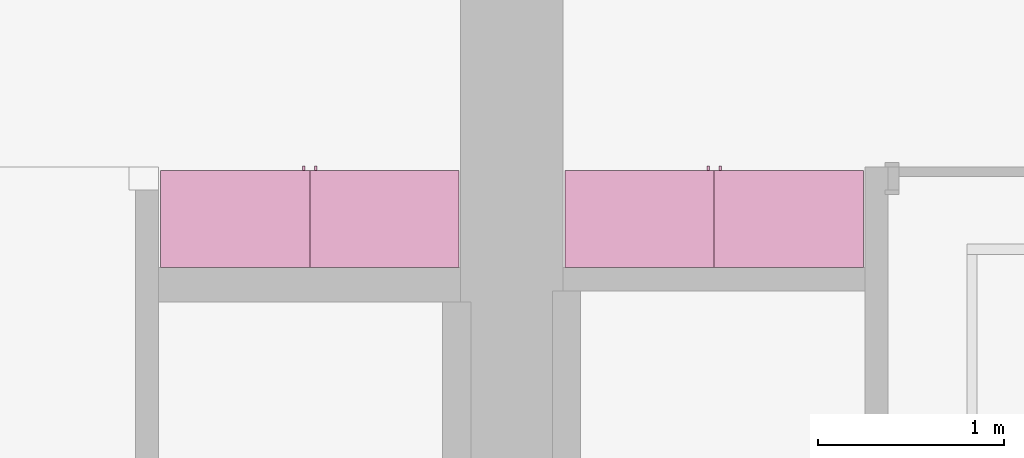
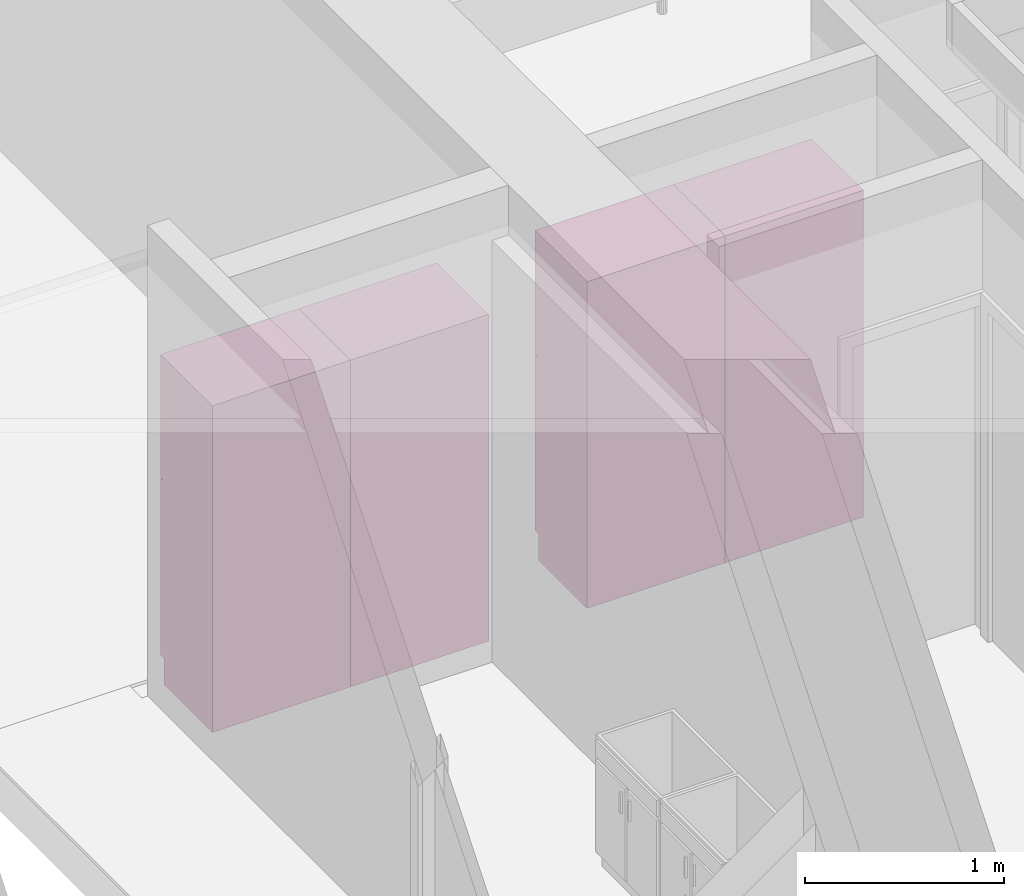
# One storey, part 12 of 12: 4 furnishings, 4 openings.
"""IFC2X3 building model written with IfcOpenShell, lengths in metres."""

from ifc_helpers import new_model, entity, si_unit, converted_unit, frame, origin, origin_2d_with_axis, place, context, project, spatial, rectangle, extrude, face_set, surface_model, source, transform, mapped, type_object, type_shapes, element, save


model = new_model("IFC2X3")

# Units and contexts
model_context = context("Model", 3, precision=1e-09, world=origin())
plan_context = context("Plan", 3, precision=1e-09, world=origin())
ifc_project = project(units=[si_unit("LENGTHUNIT", "METRE"), si_unit("AREAUNIT", "SQUARE_METRE"), si_unit("VOLUMEUNIT", "CUBIC_METRE"), converted_unit("PLANEANGLEUNIT", "DEGREE", entity("IfcRatioMeasure", 0.0174532925199433), si_unit("PLANEANGLEUNIT", "RADIAN"), dimensions=[0, 0, 0, 0, 0, 0, 0]), si_unit("TIMEUNIT", "SECOND")], contexts=[model_context, plan_context])

# Site, building, storey, space
site_placement = place(None, origin())
site = spatial("IfcSite", under=ifc_project, at=site_placement, CompositionType="ELEMENT")
building_placement = place(site_placement, origin())
building = spatial("IfcBuilding", under=site, at=building_placement, CompositionType="ELEMENT")
storey_placement = place(building_placement, frame((0.0, 0.0, 3.10000000000038)))
storey = spatial("IfcBuildingStorey", under=building, at=storey_placement, Name="Level 2", CompositionType="ELEMENT", Elevation=3.10000000000038)
space_1_placement = place(storey_placement, origin())
space_1 = spatial("IfcSpace", under=storey, at=space_1_placement, CompositionType="ELEMENT", InteriorOrExteriorSpace="INTERNAL")

# Furnishing, opening
furniture_type_1 = type_object("IfcFurnitureType", Name="800 mm", AssemblyPlace="NOTDEFINED")
shared_shape_1 = source(origin(), model_context, "Body", "SurfaceModel", [
    surface_model("IfcFaceBasedSurfaceModel", [(0.8, 0.0444499999999999, 0.161587499999842), (0.0, 0.0444500000000025, 0.161587499999842), (0.0, 0.0444500000000025, 2.0), (0.8, 0.0444499999999999, 2.0), (0.780949999999997, 0.04445, 1.98094999999995), (0.0190499999999982, 0.0444500000000025, 1.98094999999995), (0.0190499999999982, 0.0444500000000025, 0.180637499999843), (0.780949999999997, 0.04445, 0.180637499999843), (0.0, 0.545400000000002, 2.0), (0.800000000000001, 0.5454, 2.0), (0.800000000000003, 0.5454, 0.0), (0.0, 0.545400000000001, 0.0), (0.780949999999999, 0.5454, 1.98094999999995), (0.0190499999999998, 0.545400000000002, 1.98094999999995), (0.0190499999999998, 0.545400000000002, 0.180637499999843), (0.780949999999999, 0.5454, 0.180637499999843), (0.8, 0.0604000000000018, 0.161587499999842), (0.8, 0.0604000000000018, 0.0), (0.0, 0.0604000000000018, 0.0), (0.0, 0.0604000000000018, 0.161587499999832), (0.7746, 0.0, 1.37154803669582), (0.7746, 0.0, 1.26994803669581), (0.762067768369355, 0.0, 1.26994803669581), (0.762067768369355, 0.0, 1.37154803669582), (0.774599999999999, 0.0, 1.21914803669582), (0.774599999999999, 0.0, 1.11754803669582), (0.762067768369354, 0.0, 1.11754803669582), (0.762067768369354, 0.0, 1.21914803669582), (0.7746, 0.0254, 1.37154803669582), (0.7746, 0.0254, 1.26994803669581), (0.762067768369356, 0.0254000000000001, 1.26994803669581), (0.762067768369356, 0.0254000000000001, 1.37154803669582), (0.774599999999999, 0.0254, 1.21914803669582), (0.774599999999999, 0.0254, 1.11754803669582), (0.762067768369354, 0.0254000000000001, 1.11754803669582), (0.762067768369354, 0.0254000000000001, 1.21914803669582), (0.7365, 0.0381000000000001, 1.93649999999996), (0.7365, 0.0381000000000001, 1.30804803669582), (0.0635000000000013, 0.0381000000000023, 1.30804803669582), (0.0635000000000013, 0.0381000000000023, 1.93649999999996), (0.736499999999999, 0.0381000000000001, 1.18104803669581), (0.736499999999999, 0.0381000000000001, 0.22508749999984), (0.0635000000000007, 0.0381000000000023, 0.22508749999984), (0.0635000000000007, 0.0381000000000023, 1.18104803669581), (0.7365, 0.0444500000000001, 1.93649999999996), (0.7365, 0.0444500000000001, 1.30804803669582), (0.0635000000000013, 0.0444500000000023, 1.30804803669582), (0.0635000000000013, 0.0444500000000023, 1.93649999999996), (0.736499999999999, 0.0444500000000001, 1.18104803669581), (0.736499999999999, 0.0444500000000001, 0.22508749999984), (0.0635000000000007, 0.0444500000000023, 0.22508749999984), (0.0635000000000007, 0.0444500000000023, 1.18104803669581), (0.8, 0.0253999999999998, 2.0), (0.8, 0.0253999999999998, 1.24772303669581), (0.0, 0.0254000000000025, 1.24772303669581), (0.0, 0.0254000000000025, 2.0), (0.7365, 0.0254000000000001, 1.93649999999996), (0.0635000000000012, 0.0254000000000023, 1.93649999999996), (0.0635000000000012, 0.0254000000000023, 1.30804803669582), (0.7365, 0.0254000000000001, 1.30804803669582), (0.8, 0.0253999999999998, 0.161587499999821), (0.0, 0.0254000000000025, 0.161587499999821), (0.0, 0.0254000000000025, 1.24137303669581), (0.8, 0.0253999999999998, 1.24137303669581), (0.736499999999999, 0.0254000000000001, 1.18104803669582), (0.0635000000000007, 0.0254000000000023, 1.18104803669582), (0.0635000000000007, 0.0254000000000023, 0.22508749999984), (0.736499999999999, 0.0254000000000001, 0.22508749999984), (0.8, 0.0444499999999998, 2.0), (0.8, 0.0444499999999998, 1.24772303669581), (0.0, 0.0444500000000025, 1.24772303669581), (0.0, 0.0444500000000025, 2.0), (0.7365, 0.0444500000000001, 1.93649999999996), (0.0635000000000013, 0.0444500000000023, 1.93649999999996), (0.0635000000000013, 0.0444500000000023, 1.30804803669582), (0.7365, 0.0444500000000001, 1.30804803669582), (0.8, 0.0444499999999998, 0.161587499999821), (0.0, 0.0444500000000025, 0.161587499999821), (0.0, 0.0444500000000025, 1.24137303669581), (0.8, 0.0444499999999998, 1.24137303669581), (0.736499999999999, 0.0444500000000001, 1.18104803669582), (0.0635000000000007, 0.0444500000000023, 1.18104803669582), (0.0635000000000007, 0.0444500000000023, 0.22508749999984), (0.736499999999999, 0.0444500000000001, 0.22508749999984), (0.780949999999999, 0.526350000000001, 1.98094999999995), (0.780949999999999, 0.526350000000001, 0.180637499999846), (0.0190499999999999, 0.526350000000001, 0.180637499999846), (0.0190499999999998, 0.526350000000001, 1.98094999999995), (0.780949999999999, 0.545400000000001, 1.98094999999995), (0.780949999999999, 0.545400000000001, 0.180637499999846), (0.0190499999999998, 0.545400000000001, 0.180637499999846), (0.0190499999999998, 0.545400000000001, 1.98094999999995)], [face_set([[[0, 1, 2, 3], [4, 5, 6, 7]], [[8, 9, 10, 11], [12, 13, 14, 15]], [[3, 0, 16, 17, 10, 9]], [[2, 8, 9, 3]], [[1, 2, 8, 11, 18, 19]], [[0, 1, 19, 16]], [[7, 15, 12, 4]], [[6, 14, 15, 7]], [[5, 13, 14, 6]], [[4, 5, 13, 12]], [[10, 17, 18, 11]], [[18, 19, 16, 17]]]), face_set([[[20, 21, 22, 23]], [[24, 25, 26, 27]], [[28, 29, 30, 31]], [[32, 33, 34, 35]], [[23, 31, 28, 20]], [[22, 23, 31, 30]], [[21, 22, 30, 29]], [[20, 28, 29, 21]], [[27, 35, 32, 24]], [[26, 27, 35, 34]], [[25, 26, 34, 33]], [[24, 32, 33, 25]]]), face_set([[[36, 37, 38, 39]], [[40, 41, 42, 43]], [[44, 45, 46, 47]], [[48, 49, 50, 51]], [[39, 47, 44, 36]], [[38, 46, 47, 39]], [[37, 38, 46, 45]], [[36, 37, 45, 44]], [[43, 51, 48, 40]], [[42, 50, 51, 43]], [[41, 42, 50, 49]], [[40, 41, 49, 48]]]), face_set([[[52, 53, 54, 55], [56, 57, 58, 59]], [[60, 61, 62, 63], [64, 65, 66, 67]], [[68, 69, 70, 71], [72, 73, 74, 75]], [[76, 77, 78, 79], [80, 81, 82, 83]], [[55, 71, 68, 52]], [[54, 55, 71, 70]], [[53, 54, 70, 69]], [[52, 53, 69, 68]], [[63, 60, 76, 79]], [[62, 78, 79, 63]], [[61, 62, 78, 77]], [[60, 61, 77, 76]], [[59, 75, 72, 56]], [[58, 74, 75, 59]], [[57, 58, 74, 73]], [[56, 57, 73, 72]], [[67, 83, 80, 64]], [[66, 82, 83, 67]], [[65, 66, 82, 81]], [[64, 65, 81, 80]]]), face_set([[[84, 85, 86, 87]], [[88, 89, 90, 91]], [[87, 91, 88, 84]], [[86, 87, 91, 90]], [[85, 86, 90, 89]], [[84, 85, 89, 88]]])]),
])
type_shapes(furniture_type_1, [shared_shape_1])
furnishing_1_placement = place(space_1_placement, frame((6.28600000000001, -6.12060000000001, 0.0), z_axis=(0.0, 0.0, 1.0), x_axis=(-1.0, 0.0, 0.0)))
furnishing_1 = element("IfcFurnishingElement", 1, at=furnishing_1_placement, inside=space_1, type_object=furniture_type_1, ObjectType="800 mm", context=model_context, shape_type="MappedRepresentation", body=[
    mapped(shared_shape_1, transform((0.0, 0.0, 0.0), scale=1.0)),
])
opening_1_placement = place(space_1_placement, frame((6.28600000000001, -6.12060000000001, 0.0), z_axis=(0.0, 0.0, 1.0), x_axis=(-1.0, 0.0, 0.0)))
element("IfcOpeningElement", 2, at=opening_1_placement, cuts=furnishing_1, ObjectType="Opening", context=model_context, shape_type="SweptSolid", body=[
    extrude(rectangle(XDim=1.80031250000011, YDim=0.761899999999999, at=origin_2d_with_axis()), frame((-0.0187377049180267, 0.50095, -2.01920625000048), z_axis=(0.0, -1.0, 0.0), x_axis=(0.0, 0.0, -1.0)), (0.0, 0.0, 1.0), 0.50095),
])

furniture_type_2 = type_object("IfcFurnitureType", Name="800 mm", AssemblyPlace="NOTDEFINED")
shared_shape_2 = source(origin(), model_context, "Body", "SurfaceModel", [
    surface_model("IfcFaceBasedSurfaceModel", [(0.8, 0.500950000000002, 0.161587499999842), (0.8, 0.500950000000002, 2.0), (0.0, 0.50095, 2.0), (0.0, 0.50095, 0.161587499999842), (0.780949999999997, 0.500950000000002, 1.98094999999995), (0.780949999999997, 0.500950000000002, 0.180637499999843), (0.0190499999999982, 0.50095, 0.180637499999843), (0.0190499999999982, 0.50095, 1.98094999999995), (0.0, 0.0, 2.0), (0.0, 0.0, 0.0), (0.800000000000003, 0.0, 0.0), (0.800000000000001, 0.0, 2.0), (0.780949999999999, 0.0, 1.98094999999995), (0.780949999999999, 0.0, 0.180637499999843), (0.0190499999999998, 0.0, 0.180637499999843), (0.0190499999999998, 0.0, 1.98094999999995), (0.800000000000003, 0.485, 0.0), (0.8, 0.485, 0.161587499999832), (0.0, 0.485, 0.0), (0.0, 0.485, 0.161587499999842), (0.7746, 0.545400000000002, 1.37154803669582), (0.762067768369355, 0.545400000000002, 1.37154803669582), (0.762067768369355, 0.545400000000002, 1.26994803669581), (0.7746, 0.545400000000002, 1.26994803669581), (0.774599999999999, 0.545400000000002, 1.21914803669582), (0.762067768369354, 0.545400000000002, 1.21914803669582), (0.762067768369354, 0.545400000000002, 1.11754803669582), (0.774599999999999, 0.545400000000002, 1.11754803669582), (0.7746, 0.520000000000002, 1.37154803669582), (0.762067768369356, 0.520000000000002, 1.37154803669582), (0.762067768369356, 0.520000000000002, 1.26994803669581), (0.7746, 0.520000000000002, 1.26994803669581), (0.774599999999999, 0.520000000000002, 1.21914803669582), (0.762067768369354, 0.520000000000002, 1.21914803669582), (0.762067768369354, 0.520000000000002, 1.11754803669582), (0.774599999999999, 0.520000000000002, 1.11754803669582), (0.7365, 0.507300000000002, 1.93649999999996), (0.0635000000000013, 0.5073, 1.93649999999996), (0.0635000000000013, 0.5073, 1.30804803669582), (0.7365, 0.507300000000002, 1.30804803669582), (0.736499999999999, 0.507300000000002, 1.18104803669581), (0.0635000000000007, 0.5073, 1.18104803669581), (0.0635000000000007, 0.5073, 0.22508749999984), (0.736499999999999, 0.507300000000002, 0.22508749999984), (0.7365, 0.500950000000002, 1.93649999999996), (0.0635000000000013, 0.50095, 1.93649999999996), (0.0635000000000013, 0.50095, 1.30804803669582), (0.7365, 0.500950000000002, 1.30804803669582), (0.736499999999999, 0.500950000000002, 1.18104803669581), (0.0635000000000007, 0.50095, 1.18104803669581), (0.0635000000000007, 0.50095, 0.22508749999984), (0.736499999999999, 0.500950000000002, 0.22508749999984), (0.8, 0.520000000000002, 2.0), (0.0, 0.52, 2.0), (0.0, 0.52, 1.24772303669581), (0.8, 0.520000000000002, 1.24772303669581), (0.7365, 0.520000000000002, 1.93649999999996), (0.7365, 0.520000000000002, 1.30804803669582), (0.0635000000000012, 0.52, 1.30804803669582), (0.0635000000000012, 0.52, 1.93649999999996), (0.8, 0.520000000000002, 0.161587499999821), (0.8, 0.520000000000002, 1.24137303669581), (0.0, 0.52, 1.24137303669581), (0.0, 0.52, 0.161587499999821), (0.736499999999999, 0.520000000000002, 1.18104803669582), (0.736499999999999, 0.520000000000002, 0.22508749999984), (0.0635000000000007, 0.52, 0.22508749999984), (0.0635000000000007, 0.52, 1.18104803669582), (0.8, 0.500950000000002, 2.0), (0.0, 0.50095, 2.0), (0.0, 0.50095, 1.24772303669581), (0.8, 0.500950000000002, 1.24772303669581), (0.7365, 0.500950000000002, 1.93649999999996), (0.7365, 0.500950000000002, 1.30804803669582), (0.0635000000000013, 0.50095, 1.30804803669582), (0.0635000000000013, 0.50095, 1.93649999999996), (0.8, 0.500950000000002, 0.161587499999821), (0.8, 0.500950000000002, 1.24137303669581), (0.0, 0.50095, 1.24137303669581), (0.0, 0.50095, 0.161587499999821), (0.736499999999999, 0.500950000000002, 1.18104803669582), (0.736499999999999, 0.500950000000002, 0.22508749999984), (0.0635000000000007, 0.50095, 0.22508749999984), (0.0635000000000007, 0.50095, 1.18104803669582), (0.780949999999999, 0.0190500000000013, 1.98094999999995), (0.0190499999999998, 0.0190500000000013, 1.98094999999995), (0.0190499999999998, 0.0190500000000013, 0.180637499999846), (0.780949999999999, 0.0190500000000013, 0.180637499999846), (0.780949999999999, 0.0, 1.98094999999995), (0.0190499999999998, 0.0, 1.98094999999995), (0.0190499999999999, 0.0, 0.180637499999846), (0.780949999999999, 0.0, 0.180637499999846)], [face_set([[[0, 1, 2, 3], [4, 5, 6, 7]], [[8, 9, 10, 11], [12, 13, 14, 15]], [[1, 11, 10, 16, 17, 0]], [[2, 1, 11, 8]], [[3, 2, 8, 9, 18, 19]], [[0, 17, 19, 3]], [[5, 4, 12, 13]], [[6, 5, 13, 14]], [[7, 6, 14, 15]], [[4, 12, 15, 7]], [[10, 9, 18, 16]], [[18, 16, 17, 19]]]), face_set([[[20, 21, 22, 23]], [[24, 25, 26, 27]], [[28, 29, 30, 31]], [[32, 33, 34, 35]], [[21, 20, 28, 29]], [[22, 30, 29, 21]], [[23, 31, 30, 22]], [[20, 23, 31, 28]], [[25, 24, 32, 33]], [[26, 34, 33, 25]], [[27, 35, 34, 26]], [[24, 27, 35, 32]]]), face_set([[[36, 37, 38, 39]], [[40, 41, 42, 43]], [[44, 45, 46, 47]], [[48, 49, 50, 51]], [[37, 36, 44, 45]], [[38, 37, 45, 46]], [[39, 47, 46, 38]], [[36, 44, 47, 39]], [[41, 40, 48, 49]], [[42, 41, 49, 50]], [[43, 51, 50, 42]], [[40, 48, 51, 43]]]), face_set([[[52, 53, 54, 55], [56, 57, 58, 59]], [[60, 61, 62, 63], [64, 65, 66, 67]], [[68, 69, 70, 71], [72, 73, 74, 75]], [[76, 77, 78, 79], [80, 81, 82, 83]], [[53, 52, 68, 69]], [[54, 70, 69, 53]], [[55, 71, 70, 54]], [[52, 68, 71, 55]], [[61, 77, 76, 60]], [[62, 61, 77, 78]], [[63, 79, 78, 62]], [[60, 76, 79, 63]], [[57, 56, 72, 73]], [[58, 57, 73, 74]], [[59, 75, 74, 58]], [[56, 72, 75, 59]], [[65, 64, 80, 81]], [[66, 65, 81, 82]], [[67, 83, 82, 66]], [[64, 80, 83, 67]]]), face_set([[[84, 85, 86, 87]], [[88, 89, 90, 91]], [[85, 84, 88, 89]], [[86, 90, 89, 85]], [[87, 91, 90, 86]], [[84, 88, 91, 87]]])]),
])
type_shapes(furniture_type_2, [shared_shape_2])
furnishing_2_placement = place(space_1_placement, frame((4.68600000000001, -6.666, 0.0)))
furnishing_2 = element("IfcFurnishingElement", 3, at=furnishing_2_placement, inside=space_1, type_object=furniture_type_2, ObjectType="800 mm", context=model_context, shape_type="MappedRepresentation", body=[
    mapped(shared_shape_2, transform((0.0, 0.0, 0.0), scale=1.0)),
])
opening_2_placement = place(space_1_placement, frame((4.68600000000001, -6.666, 0.0)))
element("IfcOpeningElement", 4, at=opening_2_placement, cuts=furnishing_2, ObjectType="Opening", context=model_context, shape_type="SweptSolid", body=[
    extrude(rectangle(XDim=1.80031250000011, YDim=0.761899999999999, at=origin_2d_with_axis()), frame((0.0187377049180251, 0.0, -2.01920625000048), z_axis=(0.0, 1.0, 0.0), x_axis=(0.0, 0.0, -1.0)), (0.0, 0.0, 1.0), 0.50095),
])

# Space
space_2_placement = place(storey_placement, origin())
space_2 = spatial("IfcSpace", under=storey, at=space_2_placement, CompositionType="ELEMENT", InteriorOrExteriorSpace="INTERNAL")

# Furnishing, opening
furniture_type_3 = type_object("IfcFurnitureType", Name="800 mm", AssemblyPlace="NOTDEFINED")
shared_shape_3 = source(origin(), model_context, "Body", "SurfaceModel", [
    surface_model("IfcFaceBasedSurfaceModel", [(0.8, 0.0444499999999999, 0.161587499999842), (0.0, 0.0444500000000025, 0.161587499999842), (0.0, 0.0444500000000025, 2.0), (0.8, 0.0444499999999999, 2.0), (0.780949999999997, 0.04445, 1.98094999999995), (0.0190499999999982, 0.0444500000000025, 1.98094999999995), (0.0190499999999982, 0.0444500000000025, 0.180637499999843), (0.780949999999997, 0.04445, 0.180637499999843), (0.0, 0.545400000000002, 2.0), (0.800000000000001, 0.5454, 2.0), (0.800000000000003, 0.5454, 0.0), (0.0, 0.545400000000001, 0.0), (0.780949999999999, 0.5454, 1.98094999999995), (0.0190499999999998, 0.545400000000002, 1.98094999999995), (0.0190499999999998, 0.545400000000002, 0.180637499999843), (0.780949999999999, 0.5454, 0.180637499999843), (0.8, 0.0604000000000018, 0.161587499999842), (0.8, 0.0604000000000018, 0.0), (0.0, 0.0604000000000018, 0.0), (0.0, 0.0604000000000018, 0.161587499999832), (0.7746, 0.0, 1.37154803669582), (0.7746, 0.0, 1.26994803669581), (0.762067768369355, 0.0, 1.26994803669581), (0.762067768369355, 0.0, 1.37154803669582), (0.774599999999999, 0.0, 1.21914803669582), (0.774599999999999, 0.0, 1.11754803669582), (0.762067768369354, 0.0, 1.11754803669582), (0.762067768369354, 0.0, 1.21914803669582), (0.7746, 0.0254, 1.37154803669582), (0.7746, 0.0254, 1.26994803669581), (0.762067768369356, 0.0254000000000001, 1.26994803669581), (0.762067768369356, 0.0254000000000001, 1.37154803669582), (0.774599999999999, 0.0254, 1.21914803669582), (0.774599999999999, 0.0254, 1.11754803669582), (0.762067768369354, 0.0254000000000001, 1.11754803669582), (0.762067768369354, 0.0254000000000001, 1.21914803669582), (0.7365, 0.0381000000000001, 1.93649999999996), (0.7365, 0.0381000000000001, 1.30804803669582), (0.0635000000000013, 0.0381000000000023, 1.30804803669582), (0.0635000000000013, 0.0381000000000023, 1.93649999999996), (0.736499999999999, 0.0381000000000001, 1.18104803669581), (0.736499999999999, 0.0381000000000001, 0.22508749999984), (0.0635000000000007, 0.0381000000000023, 0.22508749999984), (0.0635000000000007, 0.0381000000000023, 1.18104803669581), (0.7365, 0.0444500000000001, 1.93649999999996), (0.7365, 0.0444500000000001, 1.30804803669582), (0.0635000000000013, 0.0444500000000023, 1.30804803669582), (0.0635000000000013, 0.0444500000000023, 1.93649999999996), (0.736499999999999, 0.0444500000000001, 1.18104803669581), (0.736499999999999, 0.0444500000000001, 0.22508749999984), (0.0635000000000007, 0.0444500000000023, 0.22508749999984), (0.0635000000000007, 0.0444500000000023, 1.18104803669581), (0.8, 0.0253999999999998, 2.0), (0.8, 0.0253999999999998, 1.24772303669581), (0.0, 0.0254000000000025, 1.24772303669581), (0.0, 0.0254000000000025, 2.0), (0.7365, 0.0254000000000001, 1.93649999999996), (0.0635000000000012, 0.0254000000000023, 1.93649999999996), (0.0635000000000012, 0.0254000000000023, 1.30804803669582), (0.7365, 0.0254000000000001, 1.30804803669582), (0.8, 0.0253999999999998, 0.161587499999821), (0.0, 0.0254000000000025, 0.161587499999821), (0.0, 0.0254000000000025, 1.24137303669581), (0.8, 0.0253999999999998, 1.24137303669581), (0.736499999999999, 0.0254000000000001, 1.18104803669582), (0.0635000000000007, 0.0254000000000023, 1.18104803669582), (0.0635000000000007, 0.0254000000000023, 0.22508749999984), (0.736499999999999, 0.0254000000000001, 0.22508749999984), (0.8, 0.0444499999999998, 2.0), (0.8, 0.0444499999999998, 1.24772303669581), (0.0, 0.0444500000000025, 1.24772303669581), (0.0, 0.0444500000000025, 2.0), (0.7365, 0.0444500000000001, 1.93649999999996), (0.0635000000000013, 0.0444500000000023, 1.93649999999996), (0.0635000000000013, 0.0444500000000023, 1.30804803669582), (0.7365, 0.0444500000000001, 1.30804803669582), (0.8, 0.0444499999999998, 0.161587499999821), (0.0, 0.0444500000000025, 0.161587499999821), (0.0, 0.0444500000000025, 1.24137303669581), (0.8, 0.0444499999999998, 1.24137303669581), (0.736499999999999, 0.0444500000000001, 1.18104803669582), (0.0635000000000007, 0.0444500000000023, 1.18104803669582), (0.0635000000000007, 0.0444500000000023, 0.22508749999984), (0.736499999999999, 0.0444500000000001, 0.22508749999984), (0.780949999999999, 0.526350000000001, 1.98094999999995), (0.780949999999999, 0.526350000000001, 0.180637499999846), (0.0190499999999999, 0.526350000000001, 0.180637499999846), (0.0190499999999998, 0.526350000000001, 1.98094999999995), (0.780949999999999, 0.545400000000001, 1.98094999999995), (0.780949999999999, 0.545400000000001, 0.180637499999846), (0.0190499999999998, 0.545400000000001, 0.180637499999846), (0.0190499999999998, 0.545400000000001, 1.98094999999995)], [face_set([[[0, 1, 2, 3], [4, 5, 6, 7]], [[8, 9, 10, 11], [12, 13, 14, 15]], [[3, 0, 16, 17, 10, 9]], [[2, 8, 9, 3]], [[1, 2, 8, 11, 18, 19]], [[0, 1, 19, 16]], [[7, 15, 12, 4]], [[6, 14, 15, 7]], [[5, 13, 14, 6]], [[4, 5, 13, 12]], [[10, 17, 18, 11]], [[18, 19, 16, 17]]]), face_set([[[20, 21, 22, 23]], [[24, 25, 26, 27]], [[28, 29, 30, 31]], [[32, 33, 34, 35]], [[23, 31, 28, 20]], [[22, 23, 31, 30]], [[21, 22, 30, 29]], [[20, 28, 29, 21]], [[27, 35, 32, 24]], [[26, 27, 35, 34]], [[25, 26, 34, 33]], [[24, 32, 33, 25]]]), face_set([[[36, 37, 38, 39]], [[40, 41, 42, 43]], [[44, 45, 46, 47]], [[48, 49, 50, 51]], [[39, 47, 44, 36]], [[38, 46, 47, 39]], [[37, 38, 46, 45]], [[36, 37, 45, 44]], [[43, 51, 48, 40]], [[42, 50, 51, 43]], [[41, 42, 50, 49]], [[40, 41, 49, 48]]]), face_set([[[52, 53, 54, 55], [56, 57, 58, 59]], [[60, 61, 62, 63], [64, 65, 66, 67]], [[68, 69, 70, 71], [72, 73, 74, 75]], [[76, 77, 78, 79], [80, 81, 82, 83]], [[55, 71, 68, 52]], [[54, 55, 71, 70]], [[53, 54, 70, 69]], [[52, 53, 69, 68]], [[63, 60, 76, 79]], [[62, 78, 79, 63]], [[61, 62, 78, 77]], [[60, 61, 77, 76]], [[59, 75, 72, 56]], [[58, 74, 75, 59]], [[57, 58, 74, 73]], [[56, 57, 73, 72]], [[67, 83, 80, 64]], [[66, 82, 83, 67]], [[65, 66, 82, 81]], [[64, 65, 81, 80]]]), face_set([[[84, 85, 86, 87]], [[88, 89, 90, 91]], [[87, 91, 88, 84]], [[86, 87, 91, 90]], [[85, 86, 90, 89]], [[84, 85, 89, 88]]])]),
])
type_shapes(furniture_type_3, [shared_shape_3])
furnishing_3_placement = place(space_2_placement, frame((4.11699999999999, -6.1206, 0.0), z_axis=(0.0, 0.0, 1.0), x_axis=(-1.0, 0.0, 0.0)))
furnishing_3 = element("IfcFurnishingElement", 5, at=furnishing_3_placement, inside=space_2, type_object=furniture_type_3, ObjectType="800 mm", context=model_context, shape_type="MappedRepresentation", body=[
    mapped(shared_shape_3, transform((0.0, 0.0, 0.0), scale=1.0)),
])
opening_3_placement = place(space_2_placement, frame((4.11699999999999, -6.1206, 0.0), z_axis=(0.0, 0.0, 1.0), x_axis=(-1.0, 0.0, 0.0)))
element("IfcOpeningElement", 6, at=opening_3_placement, cuts=furnishing_3, ObjectType="Opening", context=model_context, shape_type="SweptSolid", body=[
    extrude(rectangle(XDim=1.80031250000011, YDim=0.761899999999999, at=origin_2d_with_axis()), frame((-0.0187377049180267, 0.50095, -2.01920625000048), z_axis=(0.0, -1.0, 0.0), x_axis=(0.0, 0.0, -1.0)), (0.0, 0.0, 1.0), 0.50095),
])

furniture_type_4 = type_object("IfcFurnitureType", Name="800 mm", AssemblyPlace="NOTDEFINED")
shared_shape_4 = source(origin(), model_context, "Body", "SurfaceModel", [
    surface_model("IfcFaceBasedSurfaceModel", [(0.8, 0.500950000000002, 0.161587499999842), (0.8, 0.500950000000002, 2.0), (0.0, 0.50095, 2.0), (0.0, 0.50095, 0.161587499999842), (0.780949999999997, 0.500950000000002, 1.98094999999995), (0.780949999999997, 0.500950000000002, 0.180637499999843), (0.0190499999999982, 0.50095, 0.180637499999843), (0.0190499999999982, 0.50095, 1.98094999999995), (0.0, 0.0, 2.0), (0.0, 0.0, 0.0), (0.800000000000003, 0.0, 0.0), (0.800000000000001, 0.0, 2.0), (0.780949999999999, 0.0, 1.98094999999995), (0.780949999999999, 0.0, 0.180637499999843), (0.0190499999999998, 0.0, 0.180637499999843), (0.0190499999999998, 0.0, 1.98094999999995), (0.800000000000003, 0.485, 0.0), (0.8, 0.485, 0.161587499999832), (0.0, 0.485, 0.0), (0.0, 0.485, 0.161587499999842), (0.7746, 0.545400000000002, 1.37154803669582), (0.762067768369355, 0.545400000000002, 1.37154803669582), (0.762067768369355, 0.545400000000002, 1.26994803669581), (0.7746, 0.545400000000002, 1.26994803669581), (0.774599999999999, 0.545400000000002, 1.21914803669582), (0.762067768369354, 0.545400000000002, 1.21914803669582), (0.762067768369354, 0.545400000000002, 1.11754803669582), (0.774599999999999, 0.545400000000002, 1.11754803669582), (0.7746, 0.520000000000002, 1.37154803669582), (0.762067768369356, 0.520000000000002, 1.37154803669582), (0.762067768369356, 0.520000000000002, 1.26994803669581), (0.7746, 0.520000000000002, 1.26994803669581), (0.774599999999999, 0.520000000000002, 1.21914803669582), (0.762067768369354, 0.520000000000002, 1.21914803669582), (0.762067768369354, 0.520000000000002, 1.11754803669582), (0.774599999999999, 0.520000000000002, 1.11754803669582), (0.7365, 0.507300000000002, 1.93649999999996), (0.0635000000000013, 0.5073, 1.93649999999996), (0.0635000000000013, 0.5073, 1.30804803669582), (0.7365, 0.507300000000002, 1.30804803669582), (0.736499999999999, 0.507300000000002, 1.18104803669581), (0.0635000000000007, 0.5073, 1.18104803669581), (0.0635000000000007, 0.5073, 0.22508749999984), (0.736499999999999, 0.507300000000002, 0.22508749999984), (0.7365, 0.500950000000002, 1.93649999999996), (0.0635000000000013, 0.50095, 1.93649999999996), (0.0635000000000013, 0.50095, 1.30804803669582), (0.7365, 0.500950000000002, 1.30804803669582), (0.736499999999999, 0.500950000000002, 1.18104803669581), (0.0635000000000007, 0.50095, 1.18104803669581), (0.0635000000000007, 0.50095, 0.22508749999984), (0.736499999999999, 0.500950000000002, 0.22508749999984), (0.8, 0.520000000000002, 2.0), (0.0, 0.52, 2.0), (0.0, 0.52, 1.24772303669581), (0.8, 0.520000000000002, 1.24772303669581), (0.7365, 0.520000000000002, 1.93649999999996), (0.7365, 0.520000000000002, 1.30804803669582), (0.0635000000000012, 0.52, 1.30804803669582), (0.0635000000000012, 0.52, 1.93649999999996), (0.8, 0.520000000000002, 0.161587499999821), (0.8, 0.520000000000002, 1.24137303669581), (0.0, 0.52, 1.24137303669581), (0.0, 0.52, 0.161587499999821), (0.736499999999999, 0.520000000000002, 1.18104803669582), (0.736499999999999, 0.520000000000002, 0.22508749999984), (0.0635000000000007, 0.52, 0.22508749999984), (0.0635000000000007, 0.52, 1.18104803669582), (0.8, 0.500950000000002, 2.0), (0.0, 0.50095, 2.0), (0.0, 0.50095, 1.24772303669581), (0.8, 0.500950000000002, 1.24772303669581), (0.7365, 0.500950000000002, 1.93649999999996), (0.7365, 0.500950000000002, 1.30804803669582), (0.0635000000000013, 0.50095, 1.30804803669582), (0.0635000000000013, 0.50095, 1.93649999999996), (0.8, 0.500950000000002, 0.161587499999821), (0.8, 0.500950000000002, 1.24137303669581), (0.0, 0.50095, 1.24137303669581), (0.0, 0.50095, 0.161587499999821), (0.736499999999999, 0.500950000000002, 1.18104803669582), (0.736499999999999, 0.500950000000002, 0.22508749999984), (0.0635000000000007, 0.50095, 0.22508749999984), (0.0635000000000007, 0.50095, 1.18104803669582), (0.780949999999999, 0.0190500000000013, 1.98094999999995), (0.0190499999999998, 0.0190500000000013, 1.98094999999995), (0.0190499999999998, 0.0190500000000013, 0.180637499999846), (0.780949999999999, 0.0190500000000013, 0.180637499999846), (0.780949999999999, 0.0, 1.98094999999995), (0.0190499999999998, 0.0, 1.98094999999995), (0.0190499999999999, 0.0, 0.180637499999846), (0.780949999999999, 0.0, 0.180637499999846)], [face_set([[[0, 1, 2, 3], [4, 5, 6, 7]], [[8, 9, 10, 11], [12, 13, 14, 15]], [[1, 11, 10, 16, 17, 0]], [[2, 1, 11, 8]], [[3, 2, 8, 9, 18, 19]], [[0, 17, 19, 3]], [[5, 4, 12, 13]], [[6, 5, 13, 14]], [[7, 6, 14, 15]], [[4, 12, 15, 7]], [[10, 9, 18, 16]], [[18, 16, 17, 19]]]), face_set([[[20, 21, 22, 23]], [[24, 25, 26, 27]], [[28, 29, 30, 31]], [[32, 33, 34, 35]], [[21, 20, 28, 29]], [[22, 30, 29, 21]], [[23, 31, 30, 22]], [[20, 23, 31, 28]], [[25, 24, 32, 33]], [[26, 34, 33, 25]], [[27, 35, 34, 26]], [[24, 27, 35, 32]]]), face_set([[[36, 37, 38, 39]], [[40, 41, 42, 43]], [[44, 45, 46, 47]], [[48, 49, 50, 51]], [[37, 36, 44, 45]], [[38, 37, 45, 46]], [[39, 47, 46, 38]], [[36, 44, 47, 39]], [[41, 40, 48, 49]], [[42, 41, 49, 50]], [[43, 51, 50, 42]], [[40, 48, 51, 43]]]), face_set([[[52, 53, 54, 55], [56, 57, 58, 59]], [[60, 61, 62, 63], [64, 65, 66, 67]], [[68, 69, 70, 71], [72, 73, 74, 75]], [[76, 77, 78, 79], [80, 81, 82, 83]], [[53, 52, 68, 69]], [[54, 70, 69, 53]], [[55, 71, 70, 54]], [[52, 68, 71, 55]], [[61, 77, 76, 60]], [[62, 61, 77, 78]], [[63, 79, 78, 62]], [[60, 76, 79, 63]], [[57, 56, 72, 73]], [[58, 57, 73, 74]], [[59, 75, 74, 58]], [[56, 72, 75, 59]], [[65, 64, 80, 81]], [[66, 65, 81, 82]], [[67, 83, 82, 66]], [[64, 80, 83, 67]]]), face_set([[[84, 85, 86, 87]], [[88, 89, 90, 91]], [[85, 84, 88, 89]], [[86, 90, 89, 85]], [[87, 91, 90, 86]], [[84, 88, 91, 87]]])]),
])
type_shapes(furniture_type_4, [shared_shape_4])
furnishing_4_placement = place(space_2_placement, frame((2.51699999999999, -6.66599999999999, 0.0)))
furnishing_4 = element("IfcFurnishingElement", 7, at=furnishing_4_placement, inside=space_2, type_object=furniture_type_4, ObjectType="800 mm", context=model_context, shape_type="MappedRepresentation", body=[
    mapped(shared_shape_4, transform((0.0, 0.0, 0.0), scale=1.0)),
])
opening_4_placement = place(space_2_placement, frame((2.51699999999999, -6.66599999999999, 0.0)))
element("IfcOpeningElement", 8, at=opening_4_placement, cuts=furnishing_4, ObjectType="Opening", context=model_context, shape_type="SweptSolid", body=[
    extrude(rectangle(XDim=1.80031250000011, YDim=0.761899999999999, at=origin_2d_with_axis()), frame((0.0187377049180251, 0.0, -2.01920625000048), z_axis=(0.0, 1.0, 0.0), x_axis=(0.0, 0.0, -1.0)), (0.0, 0.0, 1.0), 0.50095),
])

save(model, "model.ifc")
